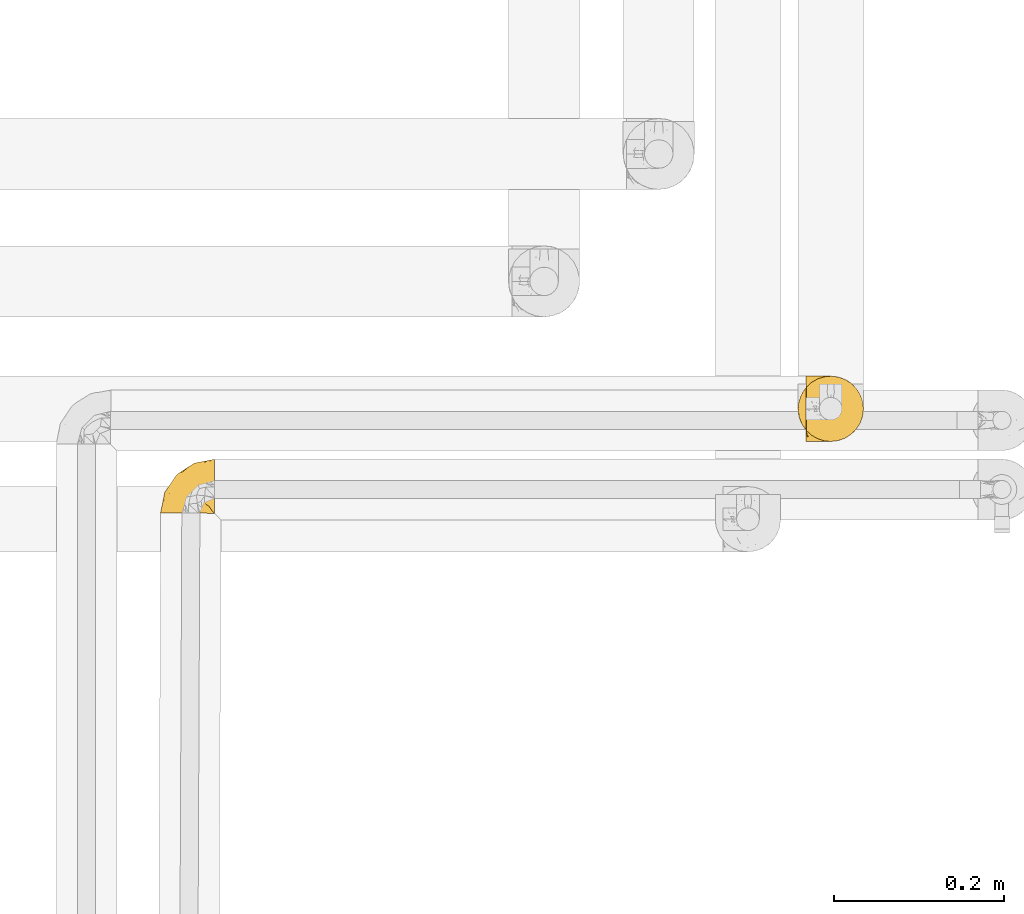
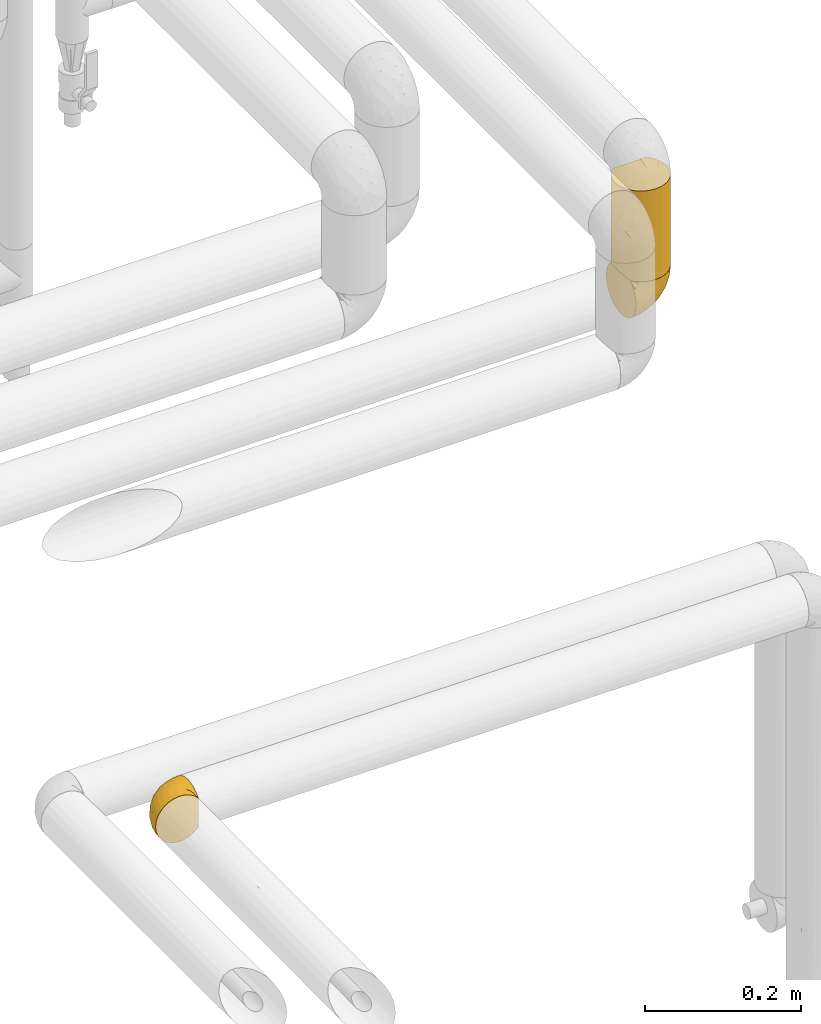
# One storey, part 89 of 827: 3 coverings.
"""IFC2X3 building model written with IfcOpenShell, lengths in millimetres."""

from ifc_helpers import new_model, entity, si_unit, converted_unit, derived_unit, direction, frame, origin, place, context, subcontext, project, spatial, faceted_brep, element, save


model = new_model("IFC2X3")

# Units and contexts
model_context = context("Model", 3, precision=0.01, world=origin(), true_north=direction((6.12303176911189e-17, 1.0)))
body_context = subcontext(model_context, "Body", "Model", "MODEL_VIEW")
ifc_project = project(units=[si_unit("LENGTHUNIT", "METRE", prefix="MILLI"), si_unit("AREAUNIT", "SQUARE_METRE"), si_unit("VOLUMEUNIT", "CUBIC_METRE"), converted_unit("PLANEANGLEUNIT", "DEGREE", entity("IfcRatioMeasure", 0.0174532925199433), si_unit("PLANEANGLEUNIT", "RADIAN"), dimensions=[0, 0, 0, 0, 0, 0, 0]), si_unit("MASSUNIT", "GRAM", prefix="KILO"), derived_unit("MASSDENSITYUNIT", [(si_unit("MASSUNIT", "GRAM", prefix="KILO"), 1), (si_unit("LENGTHUNIT", "METRE"), -3)]), derived_unit("MOMENTOFINERTIAUNIT", [(si_unit("LENGTHUNIT", "METRE"), 4)]), si_unit("TIMEUNIT", "SECOND"), si_unit("FREQUENCYUNIT", "HERTZ"), si_unit("THERMODYNAMICTEMPERATUREUNIT", "DEGREE_CELSIUS"), derived_unit("THERMALTRANSMITTANCEUNIT", [(si_unit("MASSUNIT", "GRAM", prefix="KILO"), 1), (si_unit("THERMODYNAMICTEMPERATUREUNIT", "KELVIN"), -1), (si_unit("TIMEUNIT", "SECOND"), -3)]), derived_unit("VOLUMETRICFLOWRATEUNIT", [(si_unit("LENGTHUNIT", "METRE"), 3), (si_unit("TIMEUNIT", "SECOND"), -1)]), derived_unit("MASSFLOWRATEUNIT", [(si_unit("MASSUNIT", "GRAM", prefix="KILO"), 1), (si_unit("TIMEUNIT", "SECOND"), -1)]), derived_unit("ROTATIONALFREQUENCYUNIT", [(si_unit("TIMEUNIT", "SECOND"), -1)]), si_unit("ELECTRICCURRENTUNIT", "AMPERE"), si_unit("ELECTRICVOLTAGEUNIT", "VOLT"), si_unit("POWERUNIT", "WATT"), si_unit("FORCEUNIT", "NEWTON", prefix="KILO"), si_unit("ILLUMINANCEUNIT", "LUX"), si_unit("LUMINOUSFLUXUNIT", "LUMEN"), si_unit("LUMINOUSINTENSITYUNIT", "CANDELA"), derived_unit("USERDEFINED", [(si_unit("MASSUNIT", "GRAM", prefix="KILO"), -1), (si_unit("LENGTHUNIT", "METRE"), -2), (si_unit("TIMEUNIT", "SECOND"), 3), (si_unit("LUMINOUSFLUXUNIT", "LUMEN"), 1)]), derived_unit("LINEARVELOCITYUNIT", [(si_unit("LENGTHUNIT", "METRE"), 1), (si_unit("TIMEUNIT", "SECOND"), -1)]), si_unit("PRESSUREUNIT", "PASCAL"), derived_unit("USERDEFINED", [(si_unit("LENGTHUNIT", "METRE"), -2), (si_unit("MASSUNIT", "GRAM", prefix="KILO"), 1), (si_unit("TIMEUNIT", "SECOND"), -2)]), derived_unit("LINEARFORCEUNIT", [(si_unit("MASSUNIT", "GRAM", prefix="KILO"), 1), (si_unit("LENGTHUNIT", "METRE"), 1), (si_unit("TIMEUNIT", "SECOND"), -2), (si_unit("LENGTHUNIT", "METRE"), -1)]), derived_unit("PLANARFORCEUNIT", [(si_unit("MASSUNIT", "GRAM", prefix="KILO"), 1), (si_unit("LENGTHUNIT", "METRE"), 1), (si_unit("TIMEUNIT", "SECOND"), -2), (si_unit("LENGTHUNIT", "METRE"), -2)])], contexts=[model_context])

# Site, building, storey
site_placement = place(None, origin())
site = spatial("IfcSite", under=ifc_project, at=site_placement, CompositionType="ELEMENT")
building_placement = place(site_placement, origin())
building = spatial("IfcBuilding", under=site, at=building_placement, CompositionType="ELEMENT")
storey_placement = place(building_placement, frame((0.0, 0.0, 28200.0)))
storey = spatial("IfcBuildingStorey", under=building, at=storey_placement, Name="08", CompositionType="ELEMENT", Elevation=28200.0)

# Coverings
covering_1_placement = place(storey_placement, frame((17892.46, 12825.41, 1862.75)))
element("IfcCovering", 1, at=covering_1_placement, inside=storey, Name=":ADSK_", ObjectType=":ADSK_", PredefinedType="INSULATION", context=body_context, shape_type="Brep", body=[
    faceted_brep([(59.38, 1.62, 65.19), (52.64, 1.65, 69.4), (45.13, 1.68, 72.01), (37.24, 1.72, 72.9), (29.31, 1.75, 72.0), (21.77, 1.79, 69.36), (15.01, 1.82, 65.11), (9.37, 1.84, 59.47), (5.12, 1.86, 52.71), (2.49, 1.87, 45.17), (1.6, 1.88, 37.25), (2.49, 1.87, 29.31), (5.13, 1.86, 21.77), (9.38, 1.84, 15.01), (15.02, 1.82, 9.37), (21.78, 1.79, 5.12), (29.32, 1.75, 2.49), (37.24, 1.72, 1.6), (45.15, 1.68, 2.48), (52.65, 1.65, 5.1), (59.39, 1.62, 9.31), (65.02, 1.6, 14.9), (65.02, 1.6, 16.96), (65.02, 1.6, 18.43), (65.02, 1.6, 20.19), (65.02, 1.6, 21.96), (65.02, 1.6, 23.72), (65.02, 1.6, 25.49), (65.02, 1.6, 27.25), (65.02, 1.6, 29.02), (65.02, 1.6, 30.78), (65.02, 1.6, 32.55), (65.02, 1.6, 34.31), (65.02, 1.6, 36.08), (65.02, 1.6, 37.84), (65.02, 1.6, 39.61), (65.02, 1.6, 41.37), (65.02, 1.6, 43.14), (65.02, 1.6, 45.19), (65.02, 1.6, 47.25), (65.02, 1.6, 49.31), (65.02, 1.6, 51.36), (65.02, 1.6, 53.42), (65.02, 1.6, 55.48), (65.02, 1.6, 57.53), (65.02, 1.6, 59.59), (65.24, 1.82, 14.9), (65.24, 7.46, 9.3), (65.24, 14.19, 5.09), (65.24, 21.7, 2.48), (65.24, 29.59, 1.6), (65.24, 38.82, 2.81), (65.24, 47.42, 6.37), (65.24, 54.8, 12.04), (65.24, 60.47, 19.42), (65.24, 64.03, 28.02), (65.24, 65.24, 37.25), (65.24, 64.03, 46.47), (65.24, 60.47, 55.07), (65.24, 54.8, 62.45), (65.24, 47.42, 68.12), (65.24, 38.82, 71.68), (65.24, 29.59, 72.9), (65.24, 21.7, 72.01), (65.24, 14.19, 69.4), (65.24, 7.46, 65.19), (65.24, 1.82, 59.59), (65.24, 1.82, 58.56), (65.24, 1.82, 56.8), (65.24, 1.82, 55.4), (65.24, 1.82, 54.0), (65.24, 1.82, 52.61), (65.24, 1.82, 51.21), (65.24, 1.82, 49.81), (65.24, 1.82, 48.42), (65.24, 1.82, 47.02), (65.24, 1.82, 45.62), (65.24, 1.82, 44.23), (65.24, 1.82, 42.83), (65.24, 1.82, 41.43), (65.24, 1.82, 40.04), (65.24, 1.82, 38.64), (65.24, 1.82, 37.25), (65.24, 1.82, 35.48), (65.24, 1.82, 33.72), (65.24, 1.82, 31.95), (65.24, 1.82, 30.19), (65.24, 1.82, 28.42), (65.24, 1.82, 26.66), (65.24, 1.82, 24.89), (65.24, 1.82, 23.13), (65.24, 1.82, 21.07), (65.24, 1.82, 19.01), (65.24, 1.82, 16.96), (65.08, 1.75, 50.37), (65.09, 1.76, 51.91), (65.09, 1.76, 27.73), (65.1, 1.76, 29.05), (65.08, 1.74, 22.99), (65.1, 1.76, 39.34), (65.09, 1.75, 40.69), (65.09, 1.75, 16.3), (65.09, 1.75, 17.69), (65.09, 1.75, 42.09), (65.09, 1.76, 43.53), (65.08, 1.74, 58.24), (65.09, 1.75, 59.59), (65.08, 1.74, 46.32), (65.08, 1.75, 18.99), (65.07, 1.74, 31.67), (65.09, 1.75, 30.39), (65.1, 1.76, 38.02), (65.09, 1.75, 36.65), (65.1, 1.76, 45.01), (65.08, 1.74, 35.29), (65.07, 1.74, 26.37), (65.09, 1.75, 25.1), (65.08, 1.74, 56.92), (65.13, 1.78, 32.82), (65.1, 1.76, 20.33), (65.09, 1.76, 21.66), (65.09, 1.75, 34.02), (65.1, 1.76, 53.39), (65.09, 1.75, 54.7), (65.09, 1.75, 14.9), (65.09, 1.76, 47.67), (65.09, 1.76, 49.04), (53.76, 13.13, 3.58), (57.21, 8.2, 6.24), (51.28, 25.86, 1.6), (59.77, 28.13, 1.6), (41.04, 15.67, 1.6), (61.65, 5.21, 9.92), (46.16, 20.76, 1.6), (38.73, 7.18, 1.6), (13.16, 35.82, 27.6), (5.62, 17.25, 25.47), (6.52, 26.15, 37.25), (55.4, 35.4, 2.33), (48.48, 32.75, 2.37), (39.72, 43.53, 8.51), (43.62, 53.56, 15.54), (52.39, 49.6, 8.96), (49.32, 40.07, 4.31), (58.02, 42.61, 4.31), (22.32, 20.64, 7.06), (19.18, 10.73, 7.06), (13.78, 15.1, 12.03), (39.19, 25.03, 2.3), (15.6, 34.91, 21.11), (46.73, 61.84, 30.62), (49.44, 60.45, 23.6), (4.17, 14.56, 37.25), (55.42, 57.01, 15.54), (23.93, 42.87, 18.63), (19.14, 33.46, 15.24), (32.53, 21.67, 3.14), (26.78, 11.69, 3.59), (8.17, 12.91, 18.27), (31.52, 34.35, 7.09), (38.86, 32.37, 3.87), (12.06, 25.19, 18.27), (23.06, 29.76, 9.77), (20.47, 44.34, 26.22), (38.91, 56.28, 23.04), (35.56, 56.85, 29.19), (29.07, 51.0, 24.34), (25.31, 50.45, 31.0), (20.34, 46.7, 37.25), (13.43, 36.42, 37.25), (52.55, 62.73, 37.25), (33.27, 47.51, 15.11), (27.5, 39.09, 12.03), (27.74, 26.95, 6.06), (40.95, 60.43, 37.25), (30.64, 53.56, 37.25), (54.44, 41.81, 70.18), (46.74, 61.81, 44.05), (26.42, 49.39, 49.22), (13.15, 35.8, 46.88), (13.77, 15.1, 62.45), (8.17, 12.91, 56.21), (46.14, 47.48, 65.53), (51.06, 56.06, 58.95), (35.77, 50.24, 58.15), (22.3, 20.63, 67.43), (19.17, 10.72, 67.43), (26.77, 11.69, 70.89), (19.72, 38.9, 55.09), (51.91, 33.89, 72.21), (51.28, 25.86, 72.9), (58.26, 27.73, 72.9), (38.73, 7.18, 72.9), (54.37, 62.13, 49.44), (56.56, 50.53, 65.53), (34.94, 56.49, 45.4), (43.16, 58.39, 50.89), (5.61, 17.24, 49.01), (35.79, 39.42, 66.8), (47.21, 38.57, 70.39), (12.05, 25.18, 56.21), (46.27, 30.36, 72.31), (39.96, 26.5, 72.1), (41.04, 15.67, 72.9), (46.16, 20.76, 72.9), (18.38, 26.81, 62.45), (32.52, 21.69, 71.35), (58.72, 35.69, 72.26), (27.47, 39.08, 62.45), (29.65, 30.81, 67.99), (35.21, 45.03, 62.85), (40.78, 34.09, 70.56), (53.76, 13.13, 70.91), (58.68, 9.66, 68.25), (61.64, 5.21, 64.57)], [[[0, 1, 2, 3, 4, 5, 6, 7, 8, 9, 10, 11, 12, 13, 14, 15, 16, 17, 18, 19, 20, 21, 22, 23, 24, 25, 26, 27, 28, 29, 30, 31, 32, 33, 34, 35, 36, 37, 38, 39, 40, 41, 42, 43, 44, 45]], [[46, 47, 48, 49, 50, 51, 52, 53, 54, 55, 56, 57, 58, 59, 60, 61, 62, 63, 64, 65, 66, 67, 68, 69, 70, 71, 72, 73, 74, 75, 76, 77, 78, 79, 80, 81, 82, 83, 84, 85, 86, 87, 88, 89, 90, 91, 92, 93]], [[94, 72, 95]], [[96, 87, 97]], [[25, 98, 26]], [[99, 80, 100]], [[101, 93, 102]], [[103, 104, 37]], [[105, 106, 45]], [[67, 106, 105]], [[75, 107, 76]], [[23, 102, 108]], [[85, 109, 110]], [[41, 94, 95]], [[111, 99, 34]], [[34, 33, 112]], [[22, 102, 23]], [[104, 113, 38]], [[29, 96, 97]], [[114, 112, 33]], [[115, 27, 116]], [[36, 103, 37]], [[68, 105, 117]], [[36, 100, 103]], [[84, 118, 85]], [[119, 91, 120]], [[28, 27, 115]], [[121, 32, 31]], [[122, 42, 95]], [[117, 123, 69]], [[67, 66, 106]], [[105, 44, 117]], [[122, 123, 42]], [[101, 22, 21]], [[101, 124, 46]], [[22, 101, 102]], [[125, 126, 40]], [[92, 108, 102]], [[115, 88, 96]], [[121, 114, 32]], [[102, 93, 92]], [[93, 101, 46]], [[21, 124, 101]], [[108, 24, 23]], [[119, 120, 24]], [[108, 92, 119]], [[24, 108, 119]], [[67, 105, 68]], [[44, 105, 45]], [[69, 68, 117]], [[117, 44, 43]], [[70, 123, 122]], [[123, 70, 69]], [[43, 123, 117]], [[123, 43, 42]], [[72, 71, 95]], [[71, 122, 95]], [[71, 70, 122]], [[126, 94, 40]], [[42, 41, 95]], [[75, 74, 125]], [[73, 72, 94]], [[94, 41, 40]], [[94, 126, 73]], [[74, 73, 126]], [[125, 107, 75]], [[76, 107, 113]], [[113, 107, 38]], [[39, 107, 125]], [[107, 39, 38]], [[39, 125, 40]], [[126, 125, 74]], [[78, 77, 104]], [[77, 113, 104]], [[77, 76, 113]], [[103, 78, 104]], [[38, 37, 104]], [[80, 79, 100]], [[103, 100, 79]], [[112, 111, 34]], [[100, 36, 35]], [[79, 78, 103]], [[81, 80, 99]], [[111, 81, 99]], [[35, 34, 99]], [[35, 99, 100]], [[111, 82, 81]], [[112, 82, 111]], [[112, 83, 82]], [[83, 112, 114]], [[84, 83, 121]], [[114, 33, 32]], [[114, 121, 83]], [[118, 109, 85]], [[25, 24, 120]], [[110, 109, 30]], [[30, 109, 31]], [[91, 119, 92]], [[90, 98, 120]], [[120, 91, 90]], [[28, 115, 96]], [[88, 115, 116]], [[116, 98, 89]], [[89, 88, 116]], [[28, 96, 29]], [[87, 96, 88]], [[30, 29, 110]], [[97, 87, 86]], [[90, 89, 98]], [[116, 27, 26]], [[121, 31, 118]], [[86, 85, 110]], [[110, 97, 86]], [[97, 110, 29]], [[109, 118, 31]], [[121, 118, 84]], [[120, 98, 25]], [[26, 98, 116]], [[48, 127, 49]], [[48, 47, 128]], [[49, 129, 130, 50]], [[129, 49, 127]], [[131, 127, 18]], [[46, 124, 132]], [[21, 20, 132]], [[127, 128, 19]], [[127, 131, 133, 129]], [[19, 18, 127]], [[18, 17, 134, 131]], [[46, 132, 47]], [[48, 128, 127]], [[47, 132, 128]], [[20, 128, 132]], [[124, 21, 132]], [[20, 19, 128]], [[135, 136, 137]], [[138, 129, 139]], [[140, 141, 142]], [[143, 144, 138]], [[145, 146, 147]], [[133, 148, 139]], [[134, 17, 16]], [[136, 135, 149]], [[150, 55, 151]], [[136, 11, 152]], [[153, 54, 53]], [[52, 144, 142]], [[52, 142, 53]], [[54, 153, 151]], [[144, 52, 51]], [[154, 155, 149]], [[156, 131, 157]], [[134, 16, 157]], [[13, 12, 158]], [[147, 14, 13]], [[157, 131, 134]], [[157, 16, 15]], [[146, 157, 15]], [[159, 140, 160]], [[157, 145, 156]], [[155, 147, 161]], [[155, 162, 147]], [[154, 149, 163]], [[150, 164, 165]], [[136, 12, 11]], [[137, 136, 152]], [[161, 158, 136]], [[54, 151, 55]], [[158, 147, 13]], [[166, 167, 165]], [[14, 146, 15]], [[164, 166, 165]], [[168, 135, 137, 169]], [[55, 150, 170]], [[154, 171, 172]], [[139, 148, 160]], [[51, 50, 130]], [[140, 142, 143]], [[153, 142, 141]], [[145, 162, 173]], [[156, 160, 148]], [[11, 10, 152]], [[136, 158, 12]], [[147, 158, 161]], [[147, 146, 14]], [[157, 146, 145]], [[160, 140, 143]], [[140, 172, 171]], [[139, 143, 138]], [[162, 159, 173]], [[170, 150, 174]], [[170, 56, 55]], [[167, 168, 175]], [[175, 174, 165]], [[150, 165, 174]], [[163, 167, 166]], [[175, 165, 167]], [[164, 150, 151]], [[151, 141, 164]], [[171, 164, 141]], [[154, 163, 166]], [[163, 135, 168]], [[166, 164, 171]], [[155, 154, 172]], [[166, 171, 154]], [[140, 171, 141]], [[162, 155, 172]], [[149, 155, 161]], [[159, 162, 172]], [[147, 162, 145]], [[140, 159, 172]], [[173, 160, 156]], [[136, 149, 161]], [[149, 135, 163]], [[160, 173, 159]], [[156, 148, 131]], [[156, 145, 173]], [[142, 153, 53]], [[151, 153, 141]], [[138, 51, 130]], [[142, 144, 143]], [[51, 138, 144]], [[129, 138, 130]], [[133, 139, 129]], [[160, 143, 139]], [[168, 167, 163]], [[131, 148, 133]], [[60, 176, 61]], [[174, 177, 170]], [[178, 168, 179]], [[177, 57, 170]], [[180, 181, 7]], [[182, 183, 184]], [[185, 186, 187]], [[188, 184, 178]], [[189, 190, 191]], [[4, 192, 187]], [[193, 183, 58]], [[4, 3, 192]], [[59, 194, 60]], [[60, 194, 176]], [[5, 4, 187]], [[195, 178, 196]], [[179, 137, 197]], [[182, 198, 199]], [[200, 181, 180]], [[6, 180, 7]], [[57, 177, 193]], [[197, 8, 181]], [[197, 152, 9]], [[6, 5, 186]], [[189, 201, 190]], [[202, 203, 204]], [[205, 200, 180]], [[185, 187, 206]], [[187, 203, 206]], [[8, 197, 9]], [[58, 183, 59]], [[186, 180, 6]], [[179, 197, 200]], [[205, 180, 185]], [[179, 188, 178]], [[8, 7, 181]], [[179, 168, 169, 137]], [[203, 187, 192]], [[176, 189, 207]], [[208, 209, 198]], [[209, 185, 206]], [[184, 183, 196]], [[194, 183, 182]], [[204, 201, 202]], [[209, 208, 205]], [[178, 184, 196]], [[210, 208, 198]], [[195, 196, 177]], [[179, 200, 188]], [[152, 197, 137]], [[152, 10, 9]], [[61, 207, 62]], [[197, 181, 200]], [[187, 186, 5]], [[180, 186, 185]], [[202, 209, 206]], [[201, 204, 190]], [[198, 209, 211]], [[57, 56, 170]], [[175, 195, 174]], [[177, 196, 193]], [[178, 175, 168]], [[174, 195, 177]], [[175, 178, 195]], [[183, 193, 196]], [[58, 57, 193]], [[207, 189, 191]], [[199, 189, 176]], [[205, 188, 200]], [[184, 188, 208]], [[209, 205, 185]], [[188, 205, 208]], [[62, 207, 191]], [[176, 207, 61]], [[199, 198, 211]], [[210, 182, 184]], [[183, 194, 59]], [[176, 194, 182]], [[182, 199, 176]], [[201, 199, 211]], [[199, 201, 189]], [[201, 211, 202]], [[209, 202, 211]], [[203, 202, 206]], [[182, 210, 198]], [[184, 208, 210]], [[63, 62, 191, 190]], [[64, 63, 212]], [[64, 212, 213]], [[65, 214, 66]], [[212, 190, 204, 203]], [[2, 203, 192, 3]], [[65, 213, 214]], [[1, 212, 2]], [[214, 106, 66]], [[0, 213, 1]], [[45, 106, 214]], [[65, 64, 213]], [[45, 214, 0]], [[212, 63, 190]], [[1, 213, 212]], [[203, 2, 212]], [[213, 0, 214]]]),
])
covering_2_placement = place(storey_placement, frame((18643.06, 12910.0, 2427.5)))
element("IfcCovering", 2, at=covering_2_placement, inside=storey, Name=":ADSK_", ObjectType=":ADSK_", PredefinedType="INSULATION", context=body_context, shape_type="Brep", body=[
    faceted_brep([(16.91, 9.31, 1.6), (10.9, 14.94, 1.6), (10.9, 65.05, 1.6), (16.91, 70.68, 1.6), (23.98, 74.9, 1.6), (31.79, 77.51, 1.6), (40.0, 78.4, 1.6), (49.93, 77.09, 1.6), (59.2, 73.25, 1.6), (67.15, 67.15, 1.6), (73.25, 59.2, 1.6), (77.09, 49.93, 1.6), (78.4, 40.0, 1.6), (77.09, 30.06, 1.6), (73.25, 20.8, 1.6), (67.15, 12.84, 1.6), (59.2, 6.74, 1.6), (49.93, 2.9, 1.6), (40.0, 1.6, 1.6), (31.79, 2.48, 1.6), (23.98, 5.09, 1.6), (2.9, 30.06, 143.4), (6.74, 20.8, 143.4), (12.84, 12.84, 143.4), (20.8, 6.74, 143.4), (30.06, 2.9, 143.4), (40.0, 1.6, 143.4), (49.93, 2.9, 143.4), (59.2, 6.74, 143.4), (67.15, 12.84, 143.4), (73.25, 20.8, 143.4), (77.09, 30.06, 143.4), (78.4, 40.0, 143.4), (77.51, 48.2, 143.4), (74.9, 56.01, 143.4), (70.68, 63.08, 143.4), (65.05, 69.1, 143.4), (14.94, 69.1, 143.4), (9.31, 63.08, 143.4), (5.09, 56.01, 143.4), (2.48, 48.2, 143.4), (1.6, 40.0, 143.4), (4.0, 26.63, 8.5), (2.2, 33.21, 10.29), (1.6, 40.0, 10.9), (6.92, 20.48, 5.57), (2.2, 46.78, 10.29), (4.0, 53.36, 8.5), (6.92, 59.51, 5.57), (20.48, 73.07, 139.42), (26.63, 76.0, 136.5), (33.21, 77.79, 134.7), (40.0, 78.4, 134.1), (46.78, 77.79, 134.7), (53.36, 76.0, 136.5), (59.51, 73.07, 139.42)], [[[0, 1, 2, 3, 4, 5, 6, 7, 8, 9, 10, 11, 12, 13, 14, 15, 16, 17, 18, 19, 20]], [[21, 22, 23, 24, 25, 26, 27, 28, 29, 30, 31, 32, 33, 34, 35, 36, 37, 38, 39, 40, 41]], [[26, 25, 19]], [[25, 24, 20]], [[0, 24, 23]], [[19, 18, 26]], [[20, 19, 25]], [[24, 0, 20]], [[23, 1, 0]], [[42, 22, 21]], [[21, 41, 43]], [[44, 43, 41]], [[45, 1, 22]], [[43, 42, 21]], [[45, 22, 42]], [[22, 1, 23]], [[46, 41, 40]], [[47, 40, 39]], [[48, 39, 38]], [[46, 44, 41]], [[48, 47, 39]], [[2, 48, 38]], [[46, 40, 47]], [[38, 37, 2]], [[37, 49, 3]], [[50, 51, 5]], [[49, 50, 4]], [[3, 49, 4]], [[51, 6, 5]], [[5, 4, 50]], [[6, 51, 52]], [[37, 3, 2]], [[53, 54, 7]], [[55, 36, 8]], [[54, 55, 8]], [[52, 53, 6]], [[6, 53, 7]], [[54, 8, 7]], [[36, 9, 8]], [[10, 35, 34]], [[11, 34, 33]], [[12, 33, 32]], [[9, 35, 10]], [[10, 34, 11]], [[33, 12, 11]], [[35, 9, 36]], [[13, 12, 32, 31]], [[14, 13, 31, 30]], [[30, 29, 15, 14]], [[17, 16, 28, 27]], [[18, 17, 27, 26]], [[29, 28, 16, 15]], [[44, 46, 47, 48, 2, 1, 45, 42, 43]], [[54, 53, 52, 51, 50, 49, 37, 36, 55]]]),
])
covering_3_placement = place(storey_placement, frame((18652.36, 12909.95, 2359.95)))
element("IfcCovering", 3, at=covering_3_placement, inside=storey, Name=":ADSK_", ObjectType=":ADSK_", PredefinedType="INSULATION", context=body_context, shape_type="Brep", body=[
    faceted_brep([(47.38, 5.41, 69.15), (54.67, 9.99, 69.15), (60.76, 16.08, 69.15), (65.34, 23.37, 69.15), (68.18, 31.49, 69.15), (69.15, 40.05, 69.15), (68.18, 48.61, 69.15), (65.33, 56.73, 69.15), (60.75, 64.02, 69.15), (54.66, 70.11, 69.15), (47.37, 74.69, 69.15), (39.25, 77.53, 69.15), (30.7, 78.5, 69.15), (22.59, 77.63, 69.15), (14.86, 75.08, 69.15), (7.84, 70.97, 69.15), (1.85, 65.47, 69.15), (1.85, 63.27, 69.15), (1.85, 61.53, 69.15), (1.85, 59.57, 69.15), (1.85, 57.6, 69.15), (1.85, 55.63, 69.15), (1.85, 53.67, 69.15), (1.85, 51.7, 69.15), (1.85, 49.73, 69.15), (1.85, 47.54, 69.15), (1.85, 45.34, 69.15), (1.85, 43.15, 69.15), (1.85, 40.96, 69.15), (1.85, 38.76, 69.15), (1.85, 36.57, 69.15), (1.85, 34.37, 69.15), (1.85, 32.18, 69.15), (1.85, 29.98, 69.15), (1.85, 27.79, 69.15), (1.85, 25.6, 69.15), (1.85, 23.4, 69.15), (1.85, 21.21, 69.15), (1.85, 19.01, 69.15), (1.85, 16.82, 69.15), (1.85, 14.62, 69.15), (7.85, 9.12, 69.15), (14.88, 5.0, 69.15), (22.61, 2.46, 69.15), (30.7, 1.6, 69.15), (39.26, 2.56, 69.15), (1.6, 65.47, 68.89), (1.6, 70.97, 62.89), (1.6, 75.09, 55.87), (1.6, 77.63, 48.14), (1.6, 78.5, 40.05), (1.6, 77.19, 30.09), (1.6, 73.34, 20.82), (1.6, 67.23, 12.86), (1.6, 59.27, 6.75), (1.6, 50.0, 2.91), (1.6, 40.05, 1.6), (1.6, 30.09, 2.91), (1.6, 20.82, 6.75), (1.6, 12.86, 12.86), (1.6, 6.75, 20.82), (1.6, 2.91, 30.09), (1.6, 1.6, 40.05), (1.6, 2.46, 48.14), (1.6, 5.0, 55.87), (1.6, 9.12, 62.89), (1.6, 14.62, 68.89), (1.6, 16.82, 68.89), (1.6, 17.8, 68.89), (1.6, 19.39, 68.89), (1.6, 20.98, 68.89), (1.6, 22.57, 68.89), (1.6, 24.16, 68.89), (1.6, 25.75, 68.89), (1.6, 27.33, 68.89), (1.6, 28.92, 68.89), (1.6, 30.51, 68.89), (1.6, 32.1, 68.89), (1.6, 33.69, 68.89), (1.6, 35.28, 68.89), (1.6, 36.87, 68.89), (1.6, 38.46, 68.89), (1.6, 40.05, 68.89), (1.6, 41.63, 68.89), (1.6, 43.22, 68.89), (1.6, 44.81, 68.89), (1.6, 46.4, 68.89), (1.6, 47.99, 68.89), (1.6, 49.58, 68.89), (1.6, 51.17, 68.89), (1.6, 52.76, 68.89), (1.6, 54.72, 68.89), (1.6, 56.69, 68.89), (1.6, 58.88, 68.89), (1.6, 61.08, 68.89), (1.6, 63.27, 68.89), (1.78, 37.77, 68.97), (1.77, 36.07, 68.96), (1.78, 32.96, 68.97), (1.77, 31.36, 68.97), (1.79, 56.52, 68.98), (1.78, 54.96, 68.97), (1.76, 18.75, 68.96), (1.77, 58.07, 68.96), (1.77, 50.37, 68.96), (1.76, 23.36, 68.96), (1.77, 24.95, 68.96), (1.77, 42.43, 68.96), (1.8, 15.97, 69.0), (1.76, 51.96, 68.96), (1.77, 53.47, 68.96), (1.78, 48.63, 68.97), (1.77, 63.93, 68.96), (1.77, 40.93, 68.96), (1.76, 29.72, 68.96), (1.77, 62.4, 68.97), (1.78, 60.92, 68.97), (1.77, 17.31, 68.97), (1.77, 21.74, 68.96), (1.77, 34.56, 68.96), (1.78, 20.18, 68.97), (1.77, 14.62, 68.97), (1.8, 14.62, 69.02), (1.82, 14.62, 69.08), (1.77, 65.47, 68.97), (1.72, 65.47, 68.94), (1.66, 65.47, 68.92), (1.76, 59.5, 68.96), (1.77, 47.1, 68.96), (1.76, 45.61, 68.95), (1.77, 28.18, 68.96), (1.66, 14.62, 68.92), (1.72, 14.62, 68.94), (1.78, 26.61, 68.98), (1.82, 65.47, 69.08), (1.8, 65.47, 69.02), (1.77, 39.32, 68.96), (1.78, 44.12, 68.97), (3.72, 72.26, 61.33), (7.41, 76.57, 53.1), (6.13, 71.77, 63.33), (21.47, 78.5, 49.27), (19.34, 77.9, 55.53), (26.8, 78.5, 54.6), (8.87, 78.5, 41.99), (9.2, 75.52, 57.07), (12.79, 76.13, 57.95), (14.62, 77.81, 51.56), (7.34, 78.5, 41.58), (5.33, 72.4, 61.7), (17.64, 76.56, 63.33), (7.7, 71.77, 65.0), (9.41, 72.25, 67.02), (28.75, 78.5, 61.87), (16.15, 78.5, 43.94), (14.14, 75.75, 61.21), (29.16, 78.5, 63.4), (57.02, 50.46, 33.11), (64.92, 52.75, 52.82), (64.0, 40.05, 43.3), (11.92, 77.7, 33.73), (19.16, 77.66, 36.52), (28.65, 71.02, 24.87), (24.62, 63.45, 14.17), (15.19, 70.55, 18.43), (18.36, 75.57, 28.67), (9.2, 75.57, 26.0), (46.98, 72.61, 49.25), (50.24, 72.61, 59.72), (56.1, 67.24, 55.1), (28.97, 77.74, 44.72), (54.46, 57.43, 34.15), (21.34, 47.19, 5.25), (18.4, 54.76, 6.75), (66.44, 40.05, 55.54), (12.07, 63.45, 10.47), (45.49, 60.1, 25.49), (50.57, 63.72, 35.53), (36.04, 76.83, 48.22), (42.07, 76.34, 58.71), (62.12, 60.51, 57.42), (37.37, 72.59, 34.84), (29.39, 76.05, 36.87), (53.59, 66.15, 45.01), (58.06, 60.51, 44.4), (49.27, 51.88, 23.96), (29.63, 55.34, 11.2), (33.21, 48.67, 10.56), (40.1, 53.89, 16.81), (44.08, 46.73, 17.38), (49.36, 40.05, 21.38), (56.68, 40.05, 32.34), (15.2, 40.05, 4.3), (35.57, 63.95, 20.65), (41.7, 67.24, 29.66), (46.4, 69.62, 39.6), (41.41, 73.6, 42.55), (27.45, 40.05, 6.74), (38.4, 40.05, 14.06), (12.99, 4.52, 26.84), (21.33, 32.72, 5.28), (42.89, 27.18, 18.52), (57.04, 29.63, 33.13), (56.11, 12.86, 55.1), (62.13, 19.59, 57.43), (21.89, 9.54, 20.72), (16.62, 16.64, 11.46), (32.9, 17.48, 17.69), (46.99, 7.49, 49.26), (50.25, 7.49, 59.73), (42.08, 3.75, 58.71), (49.91, 20.75, 29.72), (15.6, 2.33, 35.35), (16.15, 1.6, 43.94), (8.87, 1.6, 41.99), (29.16, 1.6, 63.4), (13.16, 26.94, 4.93), (10.83, 9.54, 17.46), (33.8, 31.21, 10.94), (25.02, 25.33, 8.92), (64.92, 27.35, 52.83), (32.83, 8.17, 29.34), (20.56, 4.3, 30.26), (58.07, 19.59, 44.4), (21.46, 2.23, 39.06), (28.1, 2.45, 43.06), (26.8, 1.6, 54.6), (21.47, 1.6, 49.27), (51.29, 12.86, 42.69), (36.04, 3.27, 48.2), (28.75, 1.6, 61.87), (8.45, 2.29, 33.44), (41.73, 12.86, 29.67), (39.27, 6.89, 38.5), (33.56, 12.43, 23.35), (27.29, 4.1, 34.97), (7.41, 3.53, 53.1), (3.51, 6.88, 59.68), (4.68, 8.16, 62.19), (5.52, 9.02, 64.11), (8.75, 5.0, 57.97), (12.79, 3.96, 57.95), (17.65, 3.52, 63.33), (13.9, 2.4, 51.77), (9.42, 7.83, 67.02), (7.68, 8.32, 64.98), (19.33, 2.19, 55.53), (14.13, 4.34, 61.22)], [[[0, 1, 2, 3, 4, 5, 6, 7, 8, 9, 10, 11, 12, 13, 14, 15, 16, 17, 18, 19, 20, 21, 22, 23, 24, 25, 26, 27, 28, 29, 30, 31, 32, 33, 34, 35, 36, 37, 38, 39, 40, 41, 42, 43, 44, 45]], [[46, 47, 48, 49, 50, 51, 52, 53, 54, 55, 56, 57, 58, 59, 60, 61, 62, 63, 64, 65, 66, 67, 68, 69, 70, 71, 72, 73, 74, 75, 76, 77, 78, 79, 80, 81, 82, 83, 84, 85, 86, 87, 88, 89, 90, 91, 92, 93, 94, 95]], [[96, 97, 30]], [[98, 77, 99]], [[100, 101, 21]], [[69, 68, 102]], [[20, 19, 103]], [[24, 23, 104]], [[20, 103, 100]], [[72, 105, 106]], [[84, 83, 107]], [[89, 88, 104]], [[108, 67, 66]], [[109, 110, 90]], [[111, 25, 24]], [[112, 17, 16]], [[82, 113, 83]], [[109, 23, 22]], [[114, 76, 75]], [[105, 36, 106]], [[104, 111, 24]], [[18, 115, 116]], [[97, 96, 80]], [[67, 108, 117]], [[105, 71, 118]], [[31, 97, 119]], [[102, 120, 69]], [[108, 121, 122, 123, 40]], [[112, 95, 115]], [[17, 115, 18]], [[94, 116, 115]], [[117, 68, 67]], [[38, 117, 39]], [[112, 124, 125, 126, 46]], [[17, 112, 115]], [[70, 120, 118]], [[39, 117, 108]], [[120, 38, 37]], [[120, 37, 118]], [[120, 70, 69]], [[116, 94, 127]], [[128, 86, 129]], [[117, 38, 102]], [[74, 130, 75]], [[99, 33, 32]], [[115, 95, 94]], [[39, 108, 40]], [[108, 66, 131, 132, 121]], [[105, 72, 71]], [[118, 37, 36]], [[71, 70, 118]], [[35, 106, 36]], [[36, 105, 118]], [[35, 133, 106]], [[74, 73, 133]], [[106, 133, 73]], [[99, 114, 33]], [[133, 35, 34]], [[73, 72, 106]], [[95, 112, 46]], [[112, 16, 134, 135, 124]], [[130, 114, 75]], [[99, 76, 114]], [[114, 130, 33]], [[34, 33, 130]], [[78, 77, 98]], [[98, 119, 78]], [[130, 133, 34]], [[133, 130, 74]], [[79, 97, 80]], [[98, 99, 32]], [[98, 32, 31]], [[77, 76, 99]], [[97, 79, 119]], [[136, 96, 29]], [[30, 97, 31]], [[136, 29, 28]], [[81, 80, 96]], [[29, 96, 30]], [[31, 119, 98]], [[119, 79, 78]], [[96, 136, 81]], [[82, 81, 136]], [[113, 107, 83]], [[84, 107, 137]], [[107, 27, 137]], [[113, 28, 107]], [[27, 107, 28]], [[85, 84, 137]], [[137, 27, 26]], [[113, 136, 28]], [[136, 113, 82]], [[109, 89, 104]], [[86, 85, 129]], [[89, 109, 90]], [[111, 87, 128]], [[26, 129, 137]], [[88, 111, 104]], [[25, 111, 128]], [[22, 110, 109]], [[23, 109, 104]], [[110, 91, 90]], [[100, 92, 101]], [[110, 22, 101]], [[91, 110, 101]], [[116, 19, 18]], [[111, 88, 87]], [[127, 103, 19]], [[25, 128, 26]], [[86, 128, 87]], [[128, 129, 26]], [[137, 129, 85]], [[120, 102, 38]], [[117, 102, 68]], [[91, 101, 92]], [[21, 101, 22]], [[93, 92, 103]], [[100, 21, 20]], [[100, 103, 92]], [[127, 93, 103]], [[93, 127, 94]], [[116, 127, 19]], [[126, 138, 47]], [[48, 138, 139]], [[140, 125, 124]], [[141, 142, 143]], [[144, 49, 139]], [[145, 140, 146]], [[48, 139, 49]], [[139, 145, 147]], [[49, 144, 148, 50]], [[126, 125, 149]], [[14, 13, 150]], [[151, 146, 140]], [[149, 140, 145]], [[152, 151, 135]], [[152, 14, 150]], [[16, 15, 134]], [[13, 153, 150]], [[124, 151, 140]], [[141, 147, 142]], [[14, 152, 15]], [[15, 152, 134]], [[47, 46, 126]], [[139, 154, 144]], [[138, 48, 47]], [[125, 140, 149]], [[135, 134, 152]], [[146, 155, 142]], [[145, 146, 147]], [[149, 139, 138]], [[147, 141, 154]], [[147, 146, 142]], [[139, 147, 154]], [[139, 149, 145]], [[149, 138, 126]], [[155, 146, 151]], [[150, 143, 142]], [[152, 155, 151]], [[150, 142, 155]], [[13, 12, 156, 153]], [[153, 143, 150]], [[152, 150, 155]], [[151, 124, 135]], [[157, 158, 159]], [[160, 154, 161]], [[162, 163, 164]], [[165, 166, 160]], [[167, 168, 169]], [[141, 170, 161]], [[156, 12, 11]], [[158, 157, 171]], [[172, 55, 173]], [[158, 6, 174]], [[175, 54, 53]], [[52, 166, 164]], [[52, 164, 53]], [[54, 175, 173]], [[166, 52, 51]], [[176, 177, 171]], [[178, 143, 179]], [[156, 11, 179]], [[8, 7, 180]], [[169, 9, 8]], [[179, 143, 153, 156]], [[179, 11, 10]], [[168, 179, 10]], [[181, 162, 182]], [[179, 167, 178]], [[183, 184, 177]], [[183, 169, 184]], [[176, 171, 185]], [[172, 186, 187]], [[158, 7, 6]], [[159, 158, 174]], [[184, 180, 158]], [[54, 173, 55]], [[180, 169, 8]], [[188, 189, 187]], [[9, 168, 10]], [[186, 188, 187]], [[190, 157, 159, 191]], [[55, 172, 192]], [[176, 193, 194]], [[161, 170, 182]], [[162, 164, 165]], [[175, 164, 163]], [[51, 50, 148]], [[167, 195, 196]], [[178, 182, 170]], [[6, 5, 174]], [[158, 180, 7]], [[169, 180, 184]], [[169, 168, 9]], [[179, 168, 167]], [[182, 162, 165]], [[162, 194, 193]], [[161, 165, 160]], [[195, 181, 196]], [[192, 172, 197]], [[192, 56, 55]], [[189, 190, 198]], [[198, 197, 187]], [[172, 187, 197]], [[185, 189, 188]], [[198, 187, 189]], [[186, 172, 173]], [[173, 163, 186]], [[193, 186, 163]], [[176, 185, 188]], [[185, 157, 190]], [[188, 186, 193]], [[177, 176, 194]], [[188, 193, 176]], [[162, 193, 163]], [[195, 177, 194]], [[171, 177, 184]], [[181, 195, 194]], [[183, 167, 169]], [[162, 181, 194]], [[196, 182, 178]], [[158, 171, 184]], [[171, 157, 185]], [[177, 195, 183]], [[167, 183, 195]], [[182, 196, 181]], [[178, 170, 143]], [[178, 167, 196]], [[164, 175, 53]], [[173, 175, 163]], [[160, 51, 148]], [[164, 166, 165]], [[51, 160, 166]], [[160, 148, 144, 154]], [[141, 161, 154]], [[182, 165, 161]], [[190, 189, 185]], [[143, 170, 141]], [[60, 199, 61]], [[197, 200, 192]], [[201, 190, 202]], [[200, 57, 192]], [[203, 204, 2]], [[205, 206, 207]], [[208, 209, 210]], [[211, 207, 201]], [[212, 213, 214]], [[45, 215, 210]], [[216, 206, 58]], [[45, 44, 215]], [[59, 217, 60]], [[60, 217, 199]], [[0, 45, 210]], [[218, 201, 219]], [[202, 159, 220]], [[205, 221, 222]], [[223, 204, 203]], [[1, 203, 2]], [[57, 200, 216]], [[220, 3, 204]], [[220, 174, 4]], [[1, 0, 209]], [[212, 224, 213]], [[225, 226, 227]], [[228, 223, 203]], [[208, 210, 229]], [[210, 226, 229]], [[3, 220, 4]], [[58, 206, 59]], [[209, 203, 1]], [[202, 220, 223]], [[228, 203, 208]], [[202, 211, 201]], [[3, 2, 204]], [[202, 190, 191, 159]], [[210, 215, 230, 226]], [[199, 212, 231]], [[232, 233, 221]], [[233, 208, 229]], [[207, 206, 219]], [[217, 206, 205]], [[227, 224, 225]], [[233, 232, 228]], [[201, 207, 219]], [[234, 232, 221]], [[218, 219, 200]], [[202, 223, 211]], [[174, 220, 159]], [[174, 5, 4]], [[61, 231, 62]], [[220, 204, 223]], [[210, 209, 0]], [[203, 209, 208]], [[225, 233, 229]], [[224, 227, 213]], [[221, 233, 235]], [[57, 56, 192]], [[198, 218, 197]], [[200, 219, 216]], [[201, 198, 190]], [[197, 218, 200]], [[198, 201, 218]], [[206, 216, 219]], [[58, 57, 216]], [[231, 212, 214]], [[222, 212, 199]], [[228, 211, 223]], [[207, 211, 232]], [[62, 231, 214]], [[199, 231, 61]], [[233, 228, 208]], [[211, 228, 232]], [[222, 221, 235]], [[234, 205, 207]], [[206, 217, 59]], [[199, 217, 205]], [[205, 222, 199]], [[224, 222, 235]], [[222, 224, 212]], [[224, 235, 225]], [[233, 225, 235]], [[226, 225, 229]], [[205, 234, 221]], [[207, 232, 234]], [[63, 214, 236]], [[214, 213, 236]], [[214, 63, 62]], [[237, 236, 238]], [[238, 132, 131]], [[236, 237, 64]], [[239, 240, 241]], [[63, 236, 64]], [[131, 66, 65]], [[237, 131, 65]], [[242, 230, 43]], [[237, 65, 64]], [[239, 121, 132]], [[42, 242, 43]], [[241, 240, 243]], [[41, 123, 244]], [[43, 230, 215, 44]], [[244, 122, 245]], [[227, 246, 243]], [[241, 247, 245]], [[121, 239, 245]], [[41, 40, 123]], [[132, 238, 239]], [[244, 42, 41]], [[131, 237, 238]], [[240, 239, 238]], [[245, 239, 241]], [[247, 241, 246]], [[247, 244, 245]], [[238, 236, 240]], [[243, 236, 213]], [[236, 243, 240]], [[227, 226, 246]], [[243, 213, 227]], [[242, 246, 226]], [[243, 246, 241]], [[246, 242, 247]], [[244, 247, 242]], [[242, 226, 230]], [[42, 244, 242]], [[122, 244, 123]], [[122, 121, 245]]]),
])

save(model, "model.ifc")
